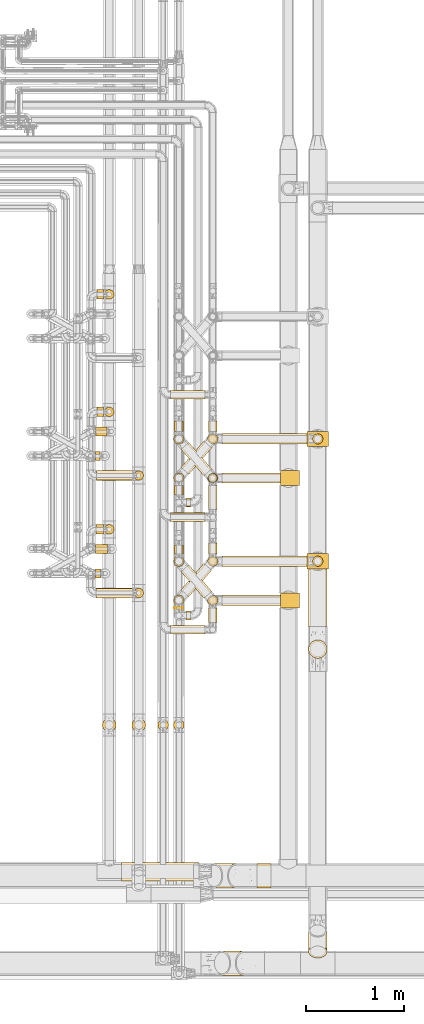
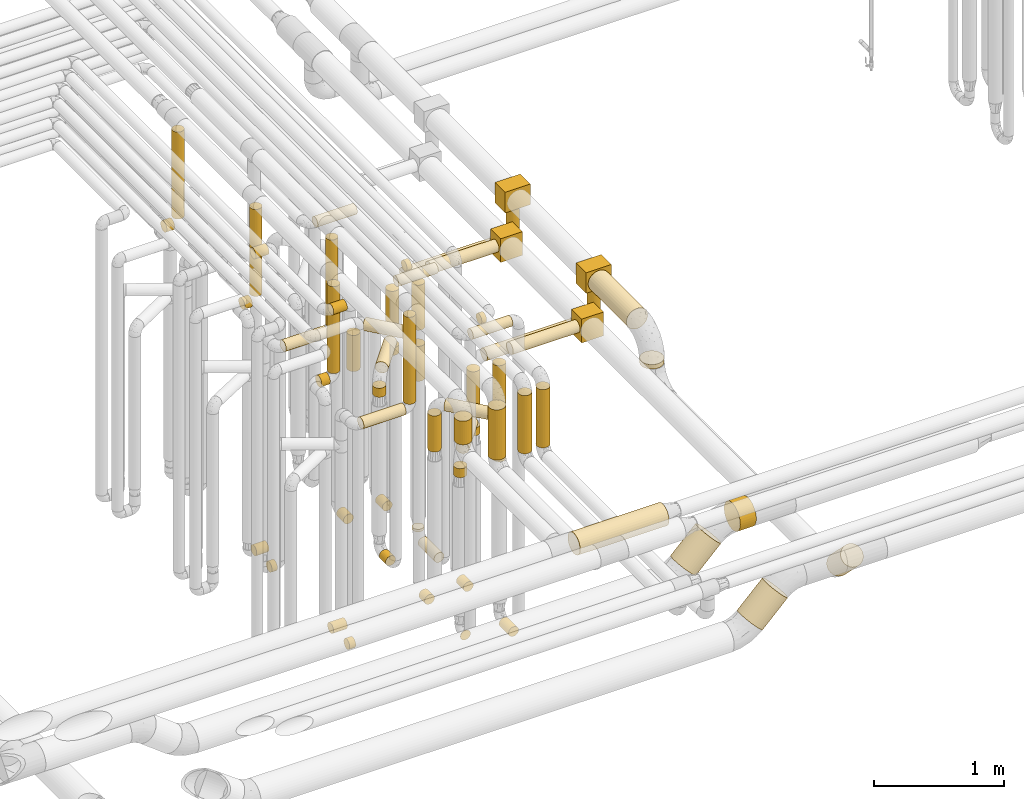
# One storey, part 12 of 827: 67 coverings.
"""IFC2X3 building model written with IfcOpenShell, lengths in millimetres."""

from ifc_helpers import new_model, entity, si_unit, converted_unit, derived_unit, direction, frame, origin, origin_2d_with_axis, place, context, subcontext, project, spatial, polyline, rectangle, circle, outline, extrude, element, save


model = new_model("IFC2X3")

# Units and contexts
model_context = context("Model", 3, precision=0.01, world=origin(), true_north=direction((6.12303176911189e-17, 1.0)))
body_context = subcontext(model_context, "Body", "Model", "MODEL_VIEW")
ifc_project = project(units=[si_unit("LENGTHUNIT", "METRE", prefix="MILLI"), si_unit("AREAUNIT", "SQUARE_METRE"), si_unit("VOLUMEUNIT", "CUBIC_METRE"), converted_unit("PLANEANGLEUNIT", "DEGREE", entity("IfcRatioMeasure", 0.0174532925199433), si_unit("PLANEANGLEUNIT", "RADIAN"), dimensions=[0, 0, 0, 0, 0, 0, 0]), si_unit("MASSUNIT", "GRAM", prefix="KILO"), derived_unit("MASSDENSITYUNIT", [(si_unit("MASSUNIT", "GRAM", prefix="KILO"), 1), (si_unit("LENGTHUNIT", "METRE"), -3)]), derived_unit("MOMENTOFINERTIAUNIT", [(si_unit("LENGTHUNIT", "METRE"), 4)]), si_unit("TIMEUNIT", "SECOND"), si_unit("FREQUENCYUNIT", "HERTZ"), si_unit("THERMODYNAMICTEMPERATUREUNIT", "DEGREE_CELSIUS"), derived_unit("THERMALTRANSMITTANCEUNIT", [(si_unit("MASSUNIT", "GRAM", prefix="KILO"), 1), (si_unit("THERMODYNAMICTEMPERATUREUNIT", "KELVIN"), -1), (si_unit("TIMEUNIT", "SECOND"), -3)]), derived_unit("VOLUMETRICFLOWRATEUNIT", [(si_unit("LENGTHUNIT", "METRE"), 3), (si_unit("TIMEUNIT", "SECOND"), -1)]), derived_unit("MASSFLOWRATEUNIT", [(si_unit("MASSUNIT", "GRAM", prefix="KILO"), 1), (si_unit("TIMEUNIT", "SECOND"), -1)]), derived_unit("ROTATIONALFREQUENCYUNIT", [(si_unit("TIMEUNIT", "SECOND"), -1)]), si_unit("ELECTRICCURRENTUNIT", "AMPERE"), si_unit("ELECTRICVOLTAGEUNIT", "VOLT"), si_unit("POWERUNIT", "WATT"), si_unit("FORCEUNIT", "NEWTON", prefix="KILO"), si_unit("ILLUMINANCEUNIT", "LUX"), si_unit("LUMINOUSFLUXUNIT", "LUMEN"), si_unit("LUMINOUSINTENSITYUNIT", "CANDELA"), derived_unit("USERDEFINED", [(si_unit("MASSUNIT", "GRAM", prefix="KILO"), -1), (si_unit("LENGTHUNIT", "METRE"), -2), (si_unit("TIMEUNIT", "SECOND"), 3), (si_unit("LUMINOUSFLUXUNIT", "LUMEN"), 1)]), derived_unit("LINEARVELOCITYUNIT", [(si_unit("LENGTHUNIT", "METRE"), 1), (si_unit("TIMEUNIT", "SECOND"), -1)]), si_unit("PRESSUREUNIT", "PASCAL"), derived_unit("USERDEFINED", [(si_unit("LENGTHUNIT", "METRE"), -2), (si_unit("MASSUNIT", "GRAM", prefix="KILO"), 1), (si_unit("TIMEUNIT", "SECOND"), -2)]), derived_unit("LINEARFORCEUNIT", [(si_unit("MASSUNIT", "GRAM", prefix="KILO"), 1), (si_unit("LENGTHUNIT", "METRE"), 1), (si_unit("TIMEUNIT", "SECOND"), -2), (si_unit("LENGTHUNIT", "METRE"), -1)]), derived_unit("PLANARFORCEUNIT", [(si_unit("MASSUNIT", "GRAM", prefix="KILO"), 1), (si_unit("LENGTHUNIT", "METRE"), 1), (si_unit("TIMEUNIT", "SECOND"), -2), (si_unit("LENGTHUNIT", "METRE"), -2)])], contexts=[model_context])

# Site, building, storey
site_placement = place(None, origin())
site = spatial("IfcSite", under=ifc_project, at=site_placement, CompositionType="ELEMENT")
building_placement = place(site_placement, origin())
building = spatial("IfcBuilding", under=site, at=building_placement, CompositionType="ELEMENT")
storey_placement = place(building_placement, frame((0.0, 0.0, 28200.0)))
storey = spatial("IfcBuildingStorey", under=building, at=storey_placement, Name="08", CompositionType="ELEMENT", Elevation=28200.0)

# Coverings
covering_1_placement = place(storey_placement, frame((35784.85, 11758.46, 352.25)))
element("IfcCovering", 1, at=covering_1_placement, inside=storey, Name=":ADSK_", ObjectType=":ADSK_", PredefinedType="INSULATION", context=body_context, shape_type="SweptSolid", body=[
    extrude(circle(Radius=46.15, at=origin_2d_with_axis()), frame((0.0, 47.75, 47.75), z_axis=(1.0, 0.0, 0.0), x_axis=(0.0, -1.0, 0.0)), (0.0, 0.0, 1.0), 110.194459668835),
])
covering_2_placement = place(storey_placement, frame((35776.05, 10558.46, 352.25)))
element("IfcCovering", 2, at=covering_2_placement, inside=storey, Name=":ADSK_", ObjectType=":ADSK_", PredefinedType="INSULATION", context=body_context, shape_type="SweptSolid", body=[
    extrude(circle(Radius=46.15, at=origin_2d_with_axis()), frame((0.0, 47.75, 47.75), z_axis=(1.0, 0.0, 0.0), x_axis=(0.0, -1.0, 0.0)), (0.0, 0.0, 1.0), 124.000000000006),
])
covering_3_placement = place(storey_placement, frame((35847.22, 8736.54, 3214.0)))
element("IfcCovering", 3, at=covering_3_placement, inside=storey, Name=":ADSK_", ObjectType=":ADSK_", PredefinedType="INSULATION", context=body_context, shape_type="SweptSolid", body=[
    extrude(circle(Radius=69.25, at=origin_2d_with_axis()), frame((70.85, 70.85, 0.0)), (0.0, 0.0, 1.0), 222.001032735806),
])
covering_4_placement = place(storey_placement, frame((35778.03, 11758.46, 3152.25)))
element("IfcCovering", 4, at=covering_4_placement, inside=storey, Name=":ADSK_", ObjectType=":ADSK_", PredefinedType="INSULATION", context=body_context, shape_type="SweptSolid", body=[
    extrude(circle(Radius=46.15, at=origin_2d_with_axis()), frame((0.0, 47.75, 47.75), z_axis=(1.0, 0.0, 0.0), x_axis=(0.0, -1.0, 0.0)), (0.0, 0.0, 1.0), 117.013860378015),
])
covering_5_placement = place(storey_placement, frame((35785.05, 10755.61, 2549.4)))
element("IfcCovering", 5, at=covering_5_placement, inside=storey, Name=":ADSK_", ObjectType=":ADSK_", PredefinedType="INSULATION", context=body_context, shape_type="SweptSolid", body=[
    extrude(circle(Radius=49.0, at=origin_2d_with_axis()), frame((0.0, 50.6, 50.6), z_axis=(1.0, -8.65020701261313e-08, 0.0), x_axis=(8.65020701261313e-08, 1.0, 0.0)), (0.0, 0.0, 1.0), 76.9274934935988),
])
covering_6_placement = place(storey_placement, frame((35868.38, 10755.61, 2657.0)))
element("IfcCovering", 6, at=covering_6_placement, inside=storey, Name=":ADSK_", ObjectType=":ADSK_", PredefinedType="INSULATION", context=body_context, shape_type="SweptSolid", body=[
    extrude(circle(Radius=49.0, at=origin_2d_with_axis()), frame((50.6, 50.6, 0.0), z_axis=(0.0, 0.0, 1.0), x_axis=(-1.0, 0.0, 0.0)), (0.0, 0.0, 1.0), 820.000867851719),
])
covering_7_placement = place(storey_placement, frame((35793.85, 11955.49, 2549.4)))
element("IfcCovering", 7, at=covering_7_placement, inside=storey, Name=":ADSK_", ObjectType=":ADSK_", PredefinedType="INSULATION", context=body_context, shape_type="SweptSolid", body=[
    extrude(circle(Radius=49.0, at=origin_2d_with_axis()), frame((0.0, 50.6, 50.6), z_axis=(1.0, -9.89978786120002e-08, 0.0), x_axis=(9.89978786120002e-08, 1.0, 0.0)), (0.0, 0.0, 1.0), 67.2173000496003),
])
covering_8_placement = place(storey_placement, frame((35867.47, 11955.49, 2657.0)))
element("IfcCovering", 8, at=covering_8_placement, inside=storey, Name=":ADSK_", ObjectType=":ADSK_", PredefinedType="INSULATION", context=body_context, shape_type="SweptSolid", body=[
    extrude(circle(Radius=49.0, at=origin_2d_with_axis()), frame((50.6, 50.6, 0.0), z_axis=(0.0, 0.0, 1.0), x_axis=(-1.0, 0.0, 0.0)), (0.0, 0.0, 1.0), 820.000751547978),
])
covering_9_placement = place(storey_placement, frame((35791.24, 13155.49, 2549.4)))
element("IfcCovering", 9, at=covering_9_placement, inside=storey, Name=":ADSK_", ObjectType=":ADSK_", PredefinedType="INSULATION", context=body_context, shape_type="SweptSolid", body=[
    extrude(circle(Radius=49.0, at=origin_2d_with_axis()), frame((0.0, 50.6, 50.6), z_axis=(1.0, -9.46746795771469e-08, -1.57223114131463e-05), x_axis=(9.46746795888483e-08, 1.0, 0.0)), (0.0, 0.0, 1.0), 70.2866927108459),
])
covering_10_placement = place(storey_placement, frame((35867.47, 13155.49, 2657.0)))
element("IfcCovering", 10, at=covering_10_placement, inside=storey, Name=":ADSK_", ObjectType=":ADSK_", PredefinedType="INSULATION", context=body_context, shape_type="SweptSolid", body=[
    extrude(circle(Radius=49.0, at=origin_2d_with_axis()), frame((51.06, 50.6, 0.03), z_axis=(-0.000562863572107548, 0.0, 0.999999841592287), x_axis=(-0.999999841592287, 0.0, -0.000562863572107548)), (0.0, 0.0, 1.0), 819.96979389611),
])
covering_11_placement = place(storey_placement, frame((35778.03, 10558.46, 3352.25)))
element("IfcCovering", 11, at=covering_11_placement, inside=storey, Name=":ADSK_", ObjectType=":ADSK_", PredefinedType="INSULATION", context=body_context, shape_type="SweptSolid", body=[
    extrude(circle(Radius=46.15, at=origin_2d_with_axis()), frame((0.0, 47.75, 47.75), z_axis=(1.0, 0.0, 0.0), x_axis=(0.0, -1.0, 0.0)), (0.0, 0.0, 1.0), 122.01386037804),
])
covering_12_placement = place(storey_placement, frame((35776.78, 11508.42, 352.25)))
element("IfcCovering", 12, at=covering_12_placement, inside=storey, Name=":ADSK_", ObjectType=":ADSK_", PredefinedType="INSULATION", context=body_context, shape_type="SweptSolid", body=[
    extrude(circle(Radius=46.15, at=origin_2d_with_axis()), frame((0.0, 47.75, 47.75), z_axis=(1.0, 0.0, 0.0), x_axis=(0.0, -1.0, 0.0)), (0.0, 0.0, 1.0), 49.0000000000149),
])
covering_13_placement = place(storey_placement, frame((35776.05, 10308.42, 352.25)))
element("IfcCovering", 13, at=covering_13_placement, inside=storey, Name=":ADSK_", ObjectType=":ADSK_", PredefinedType="INSULATION", context=body_context, shape_type="SweptSolid", body=[
    extrude(circle(Radius=46.15, at=origin_2d_with_axis()), frame((0.0, 47.75, 47.75), z_axis=(1.0, 0.0, 0.0), x_axis=(0.0, -1.0, 0.0)), (0.0, 0.0, 1.0), 54.7361396220235),
])
covering_14_placement = place(storey_placement, frame((36149.19, 8736.54, 2964.0)))
element("IfcCovering", 14, at=covering_14_placement, inside=storey, Name=":ADSK_", ObjectType=":ADSK_", PredefinedType="INSULATION", context=body_context, shape_type="SweptSolid", body=[
    extrude(circle(Radius=69.25, at=origin_2d_with_axis()), frame((70.85, 70.85, 0.0), z_axis=(0.0, 0.0, 1.0), x_axis=(-1.0, 0.0, 0.0)), (0.0, 0.0, 1.0), 472.000402937329),
])
covering_15_placement = place(storey_placement, frame((35785.05, 10105.61, 2549.4)))
element("IfcCovering", 15, at=covering_15_placement, inside=storey, Name=":ADSK_", ObjectType=":ADSK_", PredefinedType="INSULATION", context=body_context, shape_type="SweptSolid", body=[
    extrude(circle(Radius=49.0, at=origin_2d_with_axis()), frame((0.0, 50.6, 50.6), z_axis=(1.0, 0.0, 0.0), x_axis=(0.0, 1.0, 0.0)), (0.0, 0.0, 1.0), 377.986139621846),
])
covering_16_placement = place(storey_placement, frame((36169.44, 10105.61, 2657.0)))
element("IfcCovering", 16, at=covering_16_placement, inside=storey, Name=":ADSK_", ObjectType=":ADSK_", PredefinedType="INSULATION", context=body_context, shape_type="SweptSolid", body=[
    extrude(outline(polyline([(-6.4, -48.58), (6.4, -48.58), (18.75, -45.27), (29.83, -38.87), (38.87, -29.83), (45.27, -18.75), (48.58, -6.4), (48.58, 6.4), (45.27, 18.75), (38.87, 29.83), (29.83, 38.87), (18.75, 45.27), (6.4, 48.58), (-6.4, 48.58), (-18.75, 45.27), (-29.83, 38.87), (-38.87, 29.83), (-45.27, 18.75), (-48.58, 6.4), (-48.58, -6.4), (-45.27, -18.75), (-38.87, -29.83), (-29.83, -38.87), (-18.75, -45.27), (-6.4, -48.58)])), frame((50.6, 50.6, 0.0), z_axis=(0.0, -8.1150678999826e-09, 1.0), x_axis=(0.991444861373812, 0.13052619222004, 1.05920046338611e-09)), (0.0, 0.0, 1.0), 820.000297304605),
])
covering_17_placement = place(storey_placement, frame((35785.78, 11305.49, 2549.4)))
element("IfcCovering", 17, at=covering_17_placement, inside=storey, Name=":ADSK_", ObjectType=":ADSK_", PredefinedType="INSULATION", context=body_context, shape_type="SweptSolid", body=[
    extrude(circle(Radius=49.0, at=origin_2d_with_axis()), frame((0.0, 50.6, 50.6), z_axis=(1.0, 0.0, 0.0), x_axis=(0.0, 1.0, 0.0)), (0.0, 0.0, 1.0), 377.249999999815),
])
covering_18_placement = place(storey_placement, frame((36169.44, 11305.49, 2657.0)))
element("IfcCovering", 18, at=covering_18_placement, inside=storey, Name=":ADSK_", ObjectType=":ADSK_", PredefinedType="INSULATION", context=body_context, shape_type="SweptSolid", body=[
    extrude(outline(polyline([(-6.4, -48.58), (6.4, -48.58), (18.75, -45.27), (29.83, -38.87), (38.87, -29.83), (45.27, -18.75), (48.58, -6.4), (48.58, 6.4), (45.27, 18.75), (38.87, 29.83), (29.83, 38.87), (18.75, 45.27), (6.4, 48.58), (-6.4, 48.58), (-18.75, 45.27), (-29.83, 38.87), (-38.87, 29.83), (-45.27, 18.75), (-48.58, 6.4), (-48.58, -6.4), (-45.27, -18.75), (-38.87, -29.83), (-29.83, -38.87), (-18.75, -45.27), (-6.4, -48.58)])), frame((50.6, 50.6, 0.0), z_axis=(0.0, -8.1150678999826e-09, 1.0), x_axis=(0.991444861373812, 0.13052619222004, 1.05920046338611e-09)), (0.0, 0.0, 1.0), 820.000187928744),
])
covering_19_placement = place(storey_placement, frame((36546.03, 12134.58, 2953.4)))
element("IfcCovering", 19, at=covering_19_placement, inside=storey, Name=":ADSK_", ObjectType=":ADSK_", PredefinedType="INSULATION", context=body_context, shape_type="SweptSolid", body=[
    extrude(circle(Radius=45.0, at=origin_2d_with_axis()), frame((0.0, 46.6, 46.6), z_axis=(1.0, 0.0, 0.0), x_axis=(0.0, 1.0, 0.0)), (0.0, 0.0, 1.0), 352.999982000022),
])
covering_20_placement = place(storey_placement, frame((36928.44, 11007.17, 353.4)))
element("IfcCovering", 20, at=covering_20_placement, inside=storey, Name=":ADSK_", ObjectType=":ADSK_", PredefinedType="INSULATION", context=body_context, shape_type="SweptSolid", body=[
    extrude(circle(Radius=45.0, at=origin_2d_with_axis()), frame((46.6, 0.0, 46.6), z_axis=(0.0, 1.0, 0.0), x_axis=(-1.0, 0.0, 0.0)), (0.0, 0.0, 1.0), 247.028730184572),
])
covering_21_placement = place(storey_placement, frame((36928.44, 11283.61, 476.0)))
element("IfcCovering", 21, at=covering_21_placement, inside=storey, Name=":ADSK_", ObjectType=":ADSK_", PredefinedType="INSULATION", context=body_context, shape_type="SweptSolid", body=[
    extrude(circle(Radius=45.0, at=origin_2d_with_axis()), frame((46.6, 46.6, 0.0), z_axis=(0.0, 0.0, 1.0), x_axis=(0.0, -1.0, 0.0)), (0.0, 0.0, 1.0), 23.9999845046597),
])
covering_22_placement = place(storey_placement, frame((36583.05, 11806.2, 353.4)))
element("IfcCovering", 22, at=covering_22_placement, inside=storey, Name=":ADSK_", ObjectType=":ADSK_", PredefinedType="INSULATION", context=body_context, shape_type="SweptSolid", body=[
    extrude(circle(Radius=45.0, at=origin_2d_with_axis()), frame((46.6, 0.0, 46.6), z_axis=(0.0, 1.0, 0.0), x_axis=(1.0, 0.0, 0.0)), (0.0, 0.0, 1.0), 108.000000000014),
])
covering_23_placement = place(storey_placement, frame((36546.03, 10884.58, 3153.4)))
element("IfcCovering", 23, at=covering_23_placement, inside=storey, Name=":ADSK_", ObjectType=":ADSK_", PredefinedType="INSULATION", context=body_context, shape_type="SweptSolid", body=[
    extrude(circle(Radius=45.0, at=origin_2d_with_axis()), frame((0.0, 46.6, 46.6), z_axis=(1.0, 0.0, 0.0), x_axis=(0.0, -1.0, 0.0)), (0.0, 0.0, 1.0), 352.999982000069),
])
covering_24_placement = place(storey_placement, frame((36928.44, 9857.02, 353.4)))
element("IfcCovering", 24, at=covering_24_placement, inside=storey, Name=":ADSK_", ObjectType=":ADSK_", PredefinedType="INSULATION", context=body_context, shape_type="SweptSolid", body=[
    extrude(circle(Radius=45.0, at=origin_2d_with_axis()), frame((46.6, 0.0, 46.6), z_axis=(0.0, 1.0, 0.0), x_axis=(-1.0, 0.0, 0.0)), (0.0, 0.0, 1.0), 147.178757185185),
])
covering_25_placement = place(storey_placement, frame((36583.05, 10556.2, 353.4)))
element("IfcCovering", 25, at=covering_25_placement, inside=storey, Name=":ADSK_", ObjectType=":ADSK_", PredefinedType="INSULATION", context=body_context, shape_type="SweptSolid", body=[
    extrude(circle(Radius=45.0, at=origin_2d_with_axis()), frame((46.6, 0.0, 46.6), z_axis=(0.0, 1.0, 0.0), x_axis=(1.0, 0.0, 0.0)), (0.0, 0.0, 1.0), 87.5194852591066),
])
covering_26_placement = place(storey_placement, frame((36546.03, 9734.43, 3353.4)))
element("IfcCovering", 26, at=covering_26_placement, inside=storey, Name=":ADSK_", ObjectType=":ADSK_", PredefinedType="INSULATION", context=body_context, shape_type="SweptSolid", body=[
    extrude(circle(Radius=45.0, at=origin_2d_with_axis()), frame((0.0, 46.6, 46.6), z_axis=(1.0, 0.0, 0.0), x_axis=(0.0, -1.0, 0.0)), (0.0, 0.0, 1.0), 352.999982000091),
])
covering_27_placement = place(storey_placement, frame((36920.69, 11275.86, 2381.0)))
element("IfcCovering", 27, at=covering_27_placement, inside=storey, Name=":ADSK_", ObjectType=":ADSK_", PredefinedType="INSULATION", context=body_context, shape_type="SweptSolid", body=[
    extrude(circle(Radius=52.75, at=origin_2d_with_axis()), frame((54.35, 54.35, 0.0)), (0.0, 0.0, 1.0), 423.9049607946),
])
covering_28_placement = place(storey_placement, frame((37070.03, 11275.86, 2845.56)))
element("IfcCovering", 28, at=covering_28_placement, inside=storey, Name=":ADSK_", ObjectType=":ADSK_", PredefinedType="INSULATION", context=body_context, shape_type="SweptSolid", body=[
    extrude(circle(Radius=52.75, at=origin_2d_with_axis()), frame((0.0, 54.35, 54.35), z_axis=(1.0, 0.0, 3.16674345274106e-06), x_axis=(0.0, -1.0, 0.0)), (0.0, 0.0, 1.0), 595.765249593919),
])
covering_29_placement = place(storey_placement, frame((36575.3, 11675.86, 1870.0)))
element("IfcCovering", 29, at=covering_29_placement, inside=storey, Name=":ADSK_", ObjectType=":ADSK_", PredefinedType="INSULATION", context=body_context, shape_type="SweptSolid", body=[
    extrude(circle(Radius=52.75, at=origin_2d_with_axis()), frame((54.35, 54.35, 0.0), z_axis=(0.0, 0.0, 1.0), x_axis=(-1.0, 0.0, 0.0)), (0.0, 0.0, 1.0), 340.000000000014),
])
covering_30_placement = place(storey_placement, frame((36650.22, 11351.67, 2250.65)))
element("IfcCovering", 30, at=covering_30_placement, inside=storey, Name=":ADSK_", ObjectType=":ADSK_", PredefinedType="INSULATION", context=body_context, shape_type="SweptSolid", body=[
    extrude(circle(Radius=52.75, at=origin_2d_with_axis()), frame((41.52, 306.63, 54.35), z_axis=(0.65359148401651, -0.756847522306242, 0.0), x_axis=(0.756847522306242, 0.65359148401651, 0.0)), (0.0, 0.0, 1.0), 357.482862990724),
])
covering_31_placement = place(storey_placement, frame((36920.69, 11275.86, 1900.0)))
element("IfcCovering", 31, at=covering_31_placement, inside=storey, Name=":ADSK_", ObjectType=":ADSK_", PredefinedType="INSULATION", context=body_context, shape_type="SweptSolid", body=[
    extrude(circle(Radius=52.75, at=origin_2d_with_axis()), frame((54.35, 54.35, 0.0)), (0.0, 0.0, 1.0), 328.999999999994),
])
covering_32_placement = place(storey_placement, frame((36920.69, 10025.86, 2381.0)))
element("IfcCovering", 32, at=covering_32_placement, inside=storey, Name=":ADSK_", ObjectType=":ADSK_", PredefinedType="INSULATION", context=body_context, shape_type="SweptSolid", body=[
    extrude(circle(Radius=52.75, at=origin_2d_with_axis()), frame((54.35, 54.35, 0.0)), (0.0, 0.0, 1.0), 423.904960792813),
])
covering_33_placement = place(storey_placement, frame((37070.03, 10025.86, 2845.56)))
element("IfcCovering", 33, at=covering_33_placement, inside=storey, Name=":ADSK_", ObjectType=":ADSK_", PredefinedType="INSULATION", context=body_context, shape_type="SweptSolid", body=[
    extrude(circle(Radius=52.75, at=origin_2d_with_axis()), frame((0.0, 54.35, 54.35), z_axis=(1.0, 0.0, 4.67529123142557e-06), x_axis=(0.0, -1.0, 0.0)), (0.0, 0.0, 1.0), 595.765844461526),
])
covering_34_placement = place(storey_placement, frame((36575.3, 10425.86, 1870.0)))
element("IfcCovering", 34, at=covering_34_placement, inside=storey, Name=":ADSK_", ObjectType=":ADSK_", PredefinedType="INSULATION", context=body_context, shape_type="SweptSolid", body=[
    extrude(circle(Radius=52.75, at=origin_2d_with_axis()), frame((54.35, 54.35, 0.0), z_axis=(0.0, 0.0, 1.0), x_axis=(-1.0, 0.0, 0.0)), (0.0, 0.0, 1.0), 340.000000000014),
])
covering_35_placement = place(storey_placement, frame((36650.22, 10101.67, 2250.65)))
element("IfcCovering", 35, at=covering_35_placement, inside=storey, Name=":ADSK_", ObjectType=":ADSK_", PredefinedType="INSULATION", context=body_context, shape_type="SweptSolid", body=[
    extrude(circle(Radius=52.75, at=origin_2d_with_axis()), frame((41.52, 306.63, 54.35), z_axis=(0.65359148401651, -0.756847522306242, 0.0), x_axis=(0.756847522306242, 0.65359148401651, 0.0)), (0.0, 0.0, 1.0), 357.482862990724),
])
covering_36_placement = place(storey_placement, frame((36920.69, 10025.86, 1900.0)))
element("IfcCovering", 36, at=covering_36_placement, inside=storey, Name=":ADSK_", ObjectType=":ADSK_", PredefinedType="INSULATION", context=body_context, shape_type="SweptSolid", body=[
    extrude(circle(Radius=52.75, at=origin_2d_with_axis()), frame((54.35, 54.35, 0.0)), (0.0, 0.0, 1.0), 328.999999999994),
])
covering_37_placement = place(storey_placement, frame((36412.12, 8750.79, 2926.0)))
element("IfcCovering", 37, at=covering_37_placement, inside=storey, Name=":ADSK_", ObjectType=":ADSK_", PredefinedType="INSULATION", context=body_context, shape_type="SweptSolid", body=[
    extrude(circle(Radius=55.0, at=origin_2d_with_axis()), frame((56.6, 56.6, 0.0), z_axis=(0.0, 0.0, 1.0), x_axis=(0.0, -1.0, 0.0)), (0.0, 0.0, 1.0), 548.000000000049),
])
covering_38_placement = place(storey_placement, frame((36573.05, 8750.79, 2926.0)))
element("IfcCovering", 38, at=covering_38_placement, inside=storey, Name=":ADSK_", ObjectType=":ADSK_", PredefinedType="INSULATION", context=body_context, shape_type="SweptSolid", body=[
    extrude(circle(Radius=55.0, at=origin_2d_with_axis()), frame((56.6, 56.6, 0.0), z_axis=(0.0, 3.85413947979575e-08, 1.0), x_axis=(0.0, -1.0, 3.85413947979575e-08)), (0.0, 0.0, 1.0), 547.999328702734),
])
covering_39_placement = place(storey_placement, frame((37426.65, 7140.11, 2773.78)))
element("IfcCovering", 39, at=covering_39_placement, inside=storey, Name=":ADSK_", ObjectType=":ADSK_", PredefinedType="INSULATION", context=body_context, shape_type="SweptSolid", body=[
    extrude(circle(Radius=124.5, at=origin_2d_with_axis()), frame((143.64, 126.1, 126.1), z_axis=(-1.0, 0.0, 1.90022622957278e-05), x_axis=(0.0, -1.0, 0.0)), (0.0, 0.0, 1.0), 143.641200665801),
])
covering_40_placement = place(storey_placement, frame((36900.68, 7140.11, 2498.19)))
element("IfcCovering", 40, at=covering_40_placement, inside=storey, Name=":ADSK_", ObjectType=":ADSK_", PredefinedType="INSULATION", context=body_context, shape_type="SweptSolid", body=[
    extrude(circle(Radius=124.5, at=origin_2d_with_axis()), frame((89.63, 126.1, 89.63), z_axis=(0.707128324867815, 0.0, 0.707085236848881), x_axis=(0.0, -1.0, 0.0)), (0.0, 0.0, 1.0), 317.064992744885),
])
covering_41_placement = place(storey_placement, frame((37952.2, 9811.72, 2903.9)))
element("IfcCovering", 41, at=covering_41_placement, inside=storey, Name=":ADSK_", ObjectType=":ADSK_", PredefinedType="INSULATION", context=body_context, shape_type="SweptSolid", body=[
    extrude(circle(Radius=94.5, at=origin_2d_with_axis()), frame((96.1, 0.0, 96.1), z_axis=(0.0, 1.0, 0.0), x_axis=(1.0, 0.0, 0.0)), (0.0, 0.0, 1.0), 590.986619555691),
])
covering_42_placement = place(storey_placement, frame((37952.2, 9486.62, 2729.0)))
element("IfcCovering", 42, at=covering_42_placement, inside=storey, Name=":ADSK_", ObjectType=":ADSK_", PredefinedType="INSULATION", context=body_context, shape_type="SweptSolid", body=[
    extrude(circle(Radius=94.5, at=origin_2d_with_axis()), frame((96.1, 96.1, 0.0), z_axis=(0.0, 0.0, 1.0), x_axis=(-1.0, 0.0, 0.0)), (0.0, 0.0, 1.0), 42.0000000000208),
])
covering_43_placement = place(storey_placement, frame((36928.44, 11806.2, 353.4)))
element("IfcCovering", 43, at=covering_43_placement, inside=storey, Name=":ADSK_", ObjectType=":ADSK_", PredefinedType="INSULATION", context=body_context, shape_type="SweptSolid", body=[
    extrude(circle(Radius=45.0, at=origin_2d_with_axis()), frame((46.6, 0.0, 46.6), z_axis=(0.0, 1.0, 0.0), x_axis=(1.0, 0.0, 0.0)), (0.0, 0.0, 1.0), 108.000000000017),
])
covering_44_placement = place(storey_placement, frame((36920.69, 11675.86, 2126.0)))
element("IfcCovering", 44, at=covering_44_placement, inside=storey, Name=":ADSK_", ObjectType=":ADSK_", PredefinedType="INSULATION", context=body_context, shape_type="SweptSolid", body=[
    extrude(circle(Radius=52.75, at=origin_2d_with_axis()), frame((54.35, 54.35, 0.0)), (0.0, 0.0, 1.0), 378.999999999992),
])
covering_45_placement = place(storey_placement, frame((36583.05, 11157.17, 353.4)))
element("IfcCovering", 45, at=covering_45_placement, inside=storey, Name=":ADSK_", ObjectType=":ADSK_", PredefinedType="INSULATION", context=body_context, shape_type="SweptSolid", body=[
    extrude(circle(Radius=45.0, at=origin_2d_with_axis()), frame((46.6, 0.0, 46.6), z_axis=(0.0, 1.0, 0.0), x_axis=(-1.0, 0.0, 0.0)), (0.0, 0.0, 1.0), 98.4177180789936),
])
covering_46_placement = place(storey_placement, frame((36705.64, 11034.58, 3153.4)))
element("IfcCovering", 46, at=covering_46_placement, inside=storey, Name=":ADSK_", ObjectType=":ADSK_", PredefinedType="INSULATION", context=body_context, shape_type="SweptSolid", body=[
    extrude(circle(Radius=45.0, at=origin_2d_with_axis()), frame((0.0, 46.6, 46.6), z_axis=(1.0, 0.0, 0.0), x_axis=(0.0, 1.0, 0.0)), (0.0, 0.0, 1.0), 43.3898252877585),
])
covering_47_placement = place(storey_placement, frame((36928.44, 10556.2, 353.4)))
element("IfcCovering", 47, at=covering_47_placement, inside=storey, Name=":ADSK_", ObjectType=":ADSK_", PredefinedType="INSULATION", context=body_context, shape_type="SweptSolid", body=[
    extrude(circle(Radius=45.0, at=origin_2d_with_axis()), frame((46.6, 0.0, 46.6), z_axis=(0.0, 1.0, 0.0), x_axis=(1.0, 0.0, 0.0)), (0.0, 0.0, 1.0), 108.000000000017),
])
covering_48_placement = place(storey_placement, frame((36583.05, 10002.17, 353.4)))
element("IfcCovering", 48, at=covering_48_placement, inside=storey, Name=":ADSK_", ObjectType=":ADSK_", PredefinedType="INSULATION", context=body_context, shape_type="SweptSolid", body=[
    extrude(circle(Radius=45.0, at=origin_2d_with_axis()), frame((46.6, 0.0, 46.6), z_axis=(0.0, 1.0, 0.0), x_axis=(-1.0, 0.0, 0.0)), (0.0, 0.0, 1.0), 3.41771807897185),
])
covering_49_placement = place(storey_placement, frame((36705.64, 9879.58, 3353.4)))
element("IfcCovering", 49, at=covering_49_placement, inside=storey, Name=":ADSK_", ObjectType=":ADSK_", PredefinedType="INSULATION", context=body_context, shape_type="SweptSolid", body=[
    extrude(circle(Radius=45.0, at=origin_2d_with_axis()), frame((0.0, 46.6, 46.6), z_axis=(1.0, 0.0, 0.0), x_axis=(0.0, -1.0, 0.0)), (0.0, 0.0, 1.0), 43.3898252877585),
])
covering_50_placement = place(storey_placement, frame((37070.03, 11675.86, 2545.65)))
element("IfcCovering", 50, at=covering_50_placement, inside=storey, Name=":ADSK_", ObjectType=":ADSK_", PredefinedType="INSULATION", context=body_context, shape_type="SweptSolid", body=[
    extrude(circle(Radius=52.75, at=origin_2d_with_axis()), frame((0.0, 54.35, 54.35), z_axis=(1.0, 0.0, 0.0), x_axis=(0.0, 1.0, 0.0)), (0.0, 0.0, 1.0), 883.26568841584),
])
covering_51_placement = place(storey_placement, frame((36575.3, 11277.25, 1870.0)))
element("IfcCovering", 51, at=covering_51_placement, inside=storey, Name=":ADSK_", ObjectType=":ADSK_", PredefinedType="INSULATION", context=body_context, shape_type="SweptSolid", body=[
    extrude(circle(Radius=52.75, at=origin_2d_with_axis()), frame((54.35, 54.35, 0.0), z_axis=(0.0, 0.0, 1.0), x_axis=(-1.0, 0.0, 0.0)), (0.0, 0.0, 1.0), 84.9999999999937),
])
covering_52_placement = place(storey_placement, frame((36650.22, 11367.42, 1995.65)))
element("IfcCovering", 52, at=covering_52_placement, inside=storey, Name=":ADSK_", ObjectType=":ADSK_", PredefinedType="INSULATION", context=body_context, shape_type="SweptSolid", body=[
    extrude(circle(Radius=52.75, at=origin_2d_with_axis()), frame((41.52, 36.07, 54.35), z_axis=(0.653617255256319, 0.756825266247894, 0.0), x_axis=(-0.756825266247894, 0.653617255256319, 0.0)), (0.0, 0.0, 1.0), 356.436515701913),
])
covering_53_placement = place(storey_placement, frame((36920.69, 11675.86, 1900.0)))
element("IfcCovering", 53, at=covering_53_placement, inside=storey, Name=":ADSK_", ObjectType=":ADSK_", PredefinedType="INSULATION", context=body_context, shape_type="SweptSolid", body=[
    extrude(circle(Radius=52.75, at=origin_2d_with_axis()), frame((54.35, 54.35, 0.0)), (0.0, 0.0, 1.0), 74.0000000000048),
])
covering_54_placement = place(storey_placement, frame((36920.69, 10425.86, 2126.0)))
element("IfcCovering", 54, at=covering_54_placement, inside=storey, Name=":ADSK_", ObjectType=":ADSK_", PredefinedType="INSULATION", context=body_context, shape_type="SweptSolid", body=[
    extrude(circle(Radius=52.75, at=origin_2d_with_axis()), frame((54.35, 54.35, 0.0)), (0.0, 0.0, 1.0), 379.0),
])
covering_55_placement = place(storey_placement, frame((37070.03, 10425.86, 2545.65)))
element("IfcCovering", 55, at=covering_55_placement, inside=storey, Name=":ADSK_", ObjectType=":ADSK_", PredefinedType="INSULATION", context=body_context, shape_type="SweptSolid", body=[
    extrude(circle(Radius=52.75, at=origin_2d_with_axis()), frame((0.0, 54.35, 54.35), z_axis=(1.0, 0.0, 0.0), x_axis=(0.0, 1.0, 0.0)), (0.0, 0.0, 1.0), 883.26568841584),
])
covering_56_placement = place(storey_placement, frame((36575.3, 10027.25, 1870.0)))
element("IfcCovering", 56, at=covering_56_placement, inside=storey, Name=":ADSK_", ObjectType=":ADSK_", PredefinedType="INSULATION", context=body_context, shape_type="SweptSolid", body=[
    extrude(circle(Radius=52.75, at=origin_2d_with_axis()), frame((54.35, 54.35, 0.0), z_axis=(0.0, 0.0, 1.0), x_axis=(-1.0, 0.0, 0.0)), (0.0, 0.0, 1.0), 84.9999999999937),
])
covering_57_placement = place(storey_placement, frame((36650.22, 10117.42, 1995.65)))
element("IfcCovering", 57, at=covering_57_placement, inside=storey, Name=":ADSK_", ObjectType=":ADSK_", PredefinedType="INSULATION", context=body_context, shape_type="SweptSolid", body=[
    extrude(circle(Radius=52.75, at=origin_2d_with_axis()), frame((41.52, 36.07, 54.35), z_axis=(0.653617255256319, 0.756825266247894, 0.0), x_axis=(-0.756825266247894, 0.653617255256319, 0.0)), (0.0, 0.0, 1.0), 356.436515701913),
])
covering_58_placement = place(storey_placement, frame((36920.69, 10425.86, 1900.0)))
element("IfcCovering", 58, at=covering_58_placement, inside=storey, Name=":ADSK_", ObjectType=":ADSK_", PredefinedType="INSULATION", context=body_context, shape_type="SweptSolid", body=[
    extrude(circle(Radius=52.75, at=origin_2d_with_axis()), frame((54.35, 54.35, 0.0)), (0.0, 0.0, 1.0), 74.0000000000048),
])
covering_59_placement = place(storey_placement, frame((37993.7, 10425.61, 2695.0)))
element("IfcCovering", 59, at=covering_59_placement, inside=storey, Name=":ADSK_", ObjectType=":ADSK_", PredefinedType="INSULATION", context=body_context, shape_type="SweptSolid", body=[
    extrude(circle(Radius=53.0, at=origin_2d_with_axis()), frame((54.6, 54.6, 0.0), z_axis=(0.0, 0.0, 1.0), x_axis=(0.0, -1.0, 0.0)), (0.0, 0.0, 1.0), 222.500000000001),
])
covering_60_placement = place(storey_placement, frame((37936.42, 10402.7, 2917.5)))
element("IfcCovering", 60, at=covering_60_placement, inside=storey, Name=":ADSK_", ObjectType=":ADSK_", PredefinedType="INSULATION", context=body_context, shape_type="SweptSolid", body=[
    extrude(rectangle(XDim=154.999999999995, YDim=223.750000000001, at=origin_2d_with_axis()), frame((111.87, 77.5, 0.0), z_axis=(0.0, 0.0, 1.0), x_axis=(0.0, 1.0, 0.0)), (0.0, 0.0, 1.0), 194.37500000001),
])
covering_61_placement = place(storey_placement, frame((37993.7, 11675.61, 2695.0)))
element("IfcCovering", 61, at=covering_61_placement, inside=storey, Name=":ADSK_", ObjectType=":ADSK_", PredefinedType="INSULATION", context=body_context, shape_type="SweptSolid", body=[
    extrude(circle(Radius=53.0, at=origin_2d_with_axis()), frame((54.6, 54.6, 0.0), z_axis=(0.0, 0.0, 1.0), x_axis=(0.0, -1.0, 0.0)), (0.0, 0.0, 1.0), 222.499999999993),
])
covering_62_placement = place(storey_placement, frame((37936.42, 11652.7, 2917.5)))
element("IfcCovering", 62, at=covering_62_placement, inside=storey, Name=":ADSK_", ObjectType=":ADSK_", PredefinedType="INSULATION", context=body_context, shape_type="SweptSolid", body=[
    extrude(rectangle(XDim=154.999999999995, YDim=223.750000000001, at=origin_2d_with_axis()), frame((111.87, 77.5, 0.0), z_axis=(0.0, 0.0, 1.0), x_axis=(0.0, -1.0, 0.0)), (0.0, 0.0, 1.0), 194.37500000001),
])
covering_63_placement = place(storey_placement, frame((36980.46, 6248.9, 2498.24)))
element("IfcCovering", 63, at=covering_63_placement, inside=storey, Name=":ADSK_", ObjectType=":ADSK_", PredefinedType="INSULATION", context=body_context, shape_type="SweptSolid", body=[
    extrude(circle(Radius=124.5, at=origin_2d_with_axis()), frame((89.63, 126.1, 89.63), z_axis=(0.707106792500009, 0.0, 0.707106769873086), x_axis=(0.0, -1.0, 0.0)), (0.0, 0.0, 1.0), 317.157302199656),
])
covering_64_placement = place(storey_placement, frame((37952.2, 6425.38, 2497.48)))
element("IfcCovering", 64, at=covering_64_placement, inside=storey, Name=":ADSK_", ObjectType=":ADSK_", PredefinedType="INSULATION", context=body_context, shape_type="SweptSolid", body=[
    extrude(circle(Radius=94.5, at=origin_2d_with_axis()), frame((96.1, 283.72, 68.42), z_axis=(0.0, -0.707106781186546, 0.70710678118655), x_axis=(-1.0, 0.0, 0.0)), (0.0, 0.0, 1.0), 304.487373415325),
])
covering_65_placement = place(storey_placement, frame((37665.8, 11252.7, 2788.03)))
element("IfcCovering", 65, at=covering_65_placement, inside=storey, Name=":ADSK_", ObjectType=":ADSK_", PredefinedType="INSULATION", context=body_context, shape_type="SweptSolid", body=[
    extrude(rectangle(XDim=155.000000000036, YDim=194.37500000001, at=origin_2d_with_axis()), frame((97.19, 77.5, 0.0), z_axis=(0.0, 0.0, 1.0), x_axis=(0.0, -1.0, 0.0)), (0.0, 0.0, 1.0), 223.750137188377),
])
covering_66_placement = place(storey_placement, frame((37665.8, 10002.7, 2788.03)))
element("IfcCovering", 66, at=covering_66_placement, inside=storey, Name=":ADSK_", ObjectType=":ADSK_", PredefinedType="INSULATION", context=body_context, shape_type="SweptSolid", body=[
    extrude(rectangle(XDim=155.000000000038, YDim=194.37500000001, at=origin_2d_with_axis()), frame((97.19, 77.5, 0.0), z_axis=(0.0, 0.0, 1.0), x_axis=(0.0, -1.0, 0.0)), (0.0, 0.0, 1.0), 223.750137188377),
])
covering_67_placement = place(storey_placement, frame((36043.07, 7213.4, 3003.4)))
element("IfcCovering", 67, at=covering_67_placement, inside=storey, Name=":ADSK_", ObjectType=":ADSK_", PredefinedType="INSULATION", context=body_context, shape_type="SweptSolid", body=[
    extrude(circle(Radius=95.0, at=origin_2d_with_axis()), frame((0.0, 96.6, 96.6), z_axis=(1.0, 0.0, 0.0), x_axis=(0.0, -1.0, 0.0)), (0.0, 0.0, 1.0), 791.966250687601),
])

save(model, "model.ifc")
